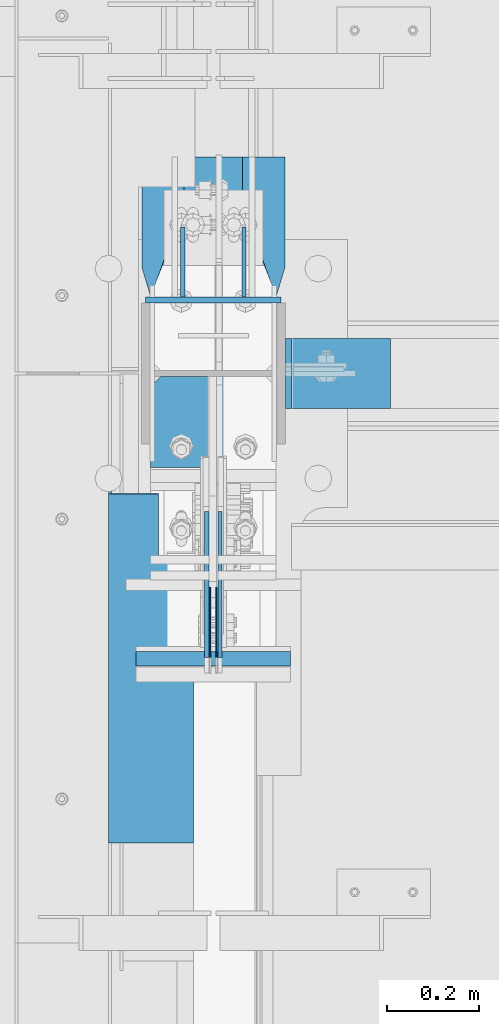
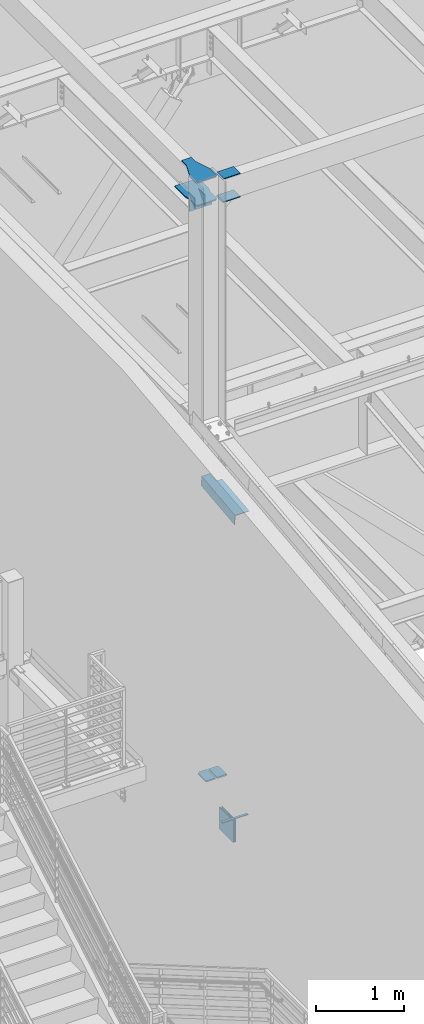
# One storey, part 870 of 1179: 15 beams, 8 elements without a shape of their own.
"""IFC2X3 building model written with IfcOpenShell, lengths in millimetres."""

from ifc_helpers import new_model, si_unit, frame, origin_with_axes, place, context, subcontext, project, spatial, faceted_brep, material, type_object, element, aggregate, save


model = new_model("IFC2X3")

# Units and contexts
model_context = context("Model", 3, precision=1e-05, world=origin_with_axes())
body_context = subcontext(model_context, "Body", "Model", "MODEL_VIEW")
ifc_project = project(units=[si_unit("LENGTHUNIT", "METRE", prefix="MILLI"), si_unit("AREAUNIT", "SQUARE_METRE"), si_unit("VOLUMEUNIT", "CUBIC_METRE"), si_unit("MASSUNIT", "GRAM", prefix="KILO"), si_unit("TIMEUNIT", "SECOND"), si_unit("PLANEANGLEUNIT", "RADIAN"), si_unit("SOLIDANGLEUNIT", "STERADIAN"), si_unit("THERMODYNAMICTEMPERATUREUNIT", "DEGREE_CELSIUS"), si_unit("LUMINOUSINTENSITYUNIT", "LUMEN")], contexts=[model_context])

# Site, building, storey
site_placement = place(None, origin_with_axes())
site = spatial("IfcSite", under=ifc_project, at=site_placement, CompositionType="ELEMENT")
building_placement = place(site_placement, origin_with_axes())
building = spatial("IfcBuilding", under=site, at=building_placement, Name="Undefined", CompositionType="ELEMENT")
storey_placement = place(building_placement, origin_with_axes())
storey = spatial("IfcBuildingStorey", under=building, at=storey_placement, Name="Undefined", CompositionType="ELEMENT", Elevation=0.0)

# Assembly, beam
assembly_1_placement = place(storey_placement, origin_with_axes())
assembly_1 = element("IfcElementAssembly", 1, at=assembly_1_placement, inside=storey, Name="BEAM", AssemblyPlace="NOTDEFINED", PredefinedType="RIGID_FRAME")
ifc_material_1 = material(Name="STEEL/A572-GR.50")
beam_type_1 = type_object("IfcBeamType", PredefinedType="NOTDEFINED")
beam_1_placement = place(assembly_1_placement, frame((431.80003662088, 33754.0407939301, 7989.4905), z_axis=(-1.0, 0.0, 0.0), x_axis=(0.0, 1.0, 0.0)))
beam_1 = element("IfcBeam", 2, at=beam_1_placement, type_object=beam_type_1, material=ifc_material_1, Name="PLATE", context=body_context, shape_type="Brep", body=[
    faceted_brep([(0.0, 4.76249999999982, -168.275000000001), (0.0, 4.76250000000073, 168.275), (31.75, 4.76249999999982, 168.275000000001), (31.75, 4.76249999999982, -168.275000000001), (0.0, -4.76250000000073, 168.275), (31.75, -4.76249999999982, 168.275000000001), (0.0, -4.76249999999982, -168.275000000001), (31.75, -4.76249999999982, -168.275000000001)], [[[0, 1, 2, 3]], [[1, 4, 5, 2]], [[4, 6, 7, 5]], [[6, 0, 3, 7]], [[5, 7, 3, 2]], [[6, 4, 1, 0]]]),
])

# Assembly, beams
assembly_2_placement = place(storey_placement, origin_with_axes())
assembly_2 = element("IfcElementAssembly", 3, at=assembly_2_placement, inside=storey, Name="COLUMN", AssemblyPlace="NOTDEFINED", PredefinedType="RIGID_FRAME")
ifc_material_2 = material(Name="STEEL/A36")
beam_type_2 = type_object("IfcBeamType", PredefinedType="NOTDEFINED")
beam_2_placement = place(assembly_2_placement, frame((579.437499999999, 34551.9375000406, 16030.575), z_axis=(0.0, 0.0, 1.0), x_axis=(-1.0, 0.0, 0.0)))
beam_2 = element("IfcBeam", 4, at=beam_2_placement, type_object=beam_type_2, material=ifc_material_2, Name="PLATE", context=body_context, shape_type="Brep", body=[
    faceted_brep([(-7.27595761418343e-12, 6.35000000000036, -76.1999999999971), (0.0, 6.35000000000036, 76.2000000000044), (295.274999999994, 6.34999999999854, 76.2000000000007), (295.274999999994, 6.34999999999854, -76.2000000000007), (0.0, -6.35000000000036, 76.2000000000044), (295.274999999994, -6.34999999999854, 76.2000000000007), (7.27595761418343e-12, -6.35000000000036, -76.1999999999971), (295.274999999994, -6.34999999999854, -76.2000000000007)], [[[0, 1, 2, 3]], [[1, 4, 5, 2]], [[4, 6, 7, 5]], [[6, 0, 3, 7]], [[5, 7, 3, 2]], [[6, 4, 1, 0]]]),
])
beam_3_placement = place(assembly_2_placement, frame((817.562493896483, 34391.6, 16116.3), z_axis=(0.0, 1.0, 0.0), x_axis=(-1.0, 0.0, 0.0)))
beam_3 = element("IfcBeam", 5, at=beam_3_placement, type_object=beam_type_2, material=ifc_material_2, Name="PLATE", context=body_context, shape_type="Brep", body=[
    faceted_brep([(215.900000000001, 6.35000000000036, 76.2000000000007), (228.599999999999, -6.35000000000036, 76.2000000000007), (228.599999999999, -6.35000000000036, -76.2000000000007), (215.900000000001, 6.35000000000036, -76.2000000000007), (-7.27595761418343e-12, 6.35000000000036, -76.1999999999971), (0.0, 6.35000000000036, 76.2000000000044), (0.0, -6.35000000000036, 76.2000000000044), (7.27595761418343e-12, -6.35000000000036, -76.1999999999971)], [[[0, 1, 2, 3]], [[4, 5, 0, 3]], [[5, 6, 1, 0]], [[6, 7, 2, 1]], [[7, 4, 3, 2]], [[7, 6, 5, 4]]]),
])
beam_4_placement = place(assembly_2_placement, frame((817.562494014754, 34391.6, 16435.3875), z_axis=(0.0, 1.0, 0.0), x_axis=(-1.0, 0.0, 0.0)))
beam_4 = element("IfcBeam", 6, at=beam_4_placement, type_object=beam_type_2, material=ifc_material_2, Name="PLATE", context=body_context, shape_type="Brep", body=[
    faceted_brep([(215.900000000001, 6.35000000000036, 76.2000000000007), (228.599999999999, -6.35000000000036, 76.2000000000007), (228.599999999999, -6.35000000000036, -76.2000000000007), (215.900000000001, 6.35000000000036, -76.2000000000007), (-7.27595761418343e-12, 6.35000000000036, -76.1999999999971), (0.0, 6.35000000000036, 76.2000000000044), (0.0, -6.35000000000036, 76.2000000000044), (7.27595761418343e-12, -6.35000000000036, -76.1999999999971)], [[[0, 1, 2, 3]], [[4, 5, 0, 3]], [[5, 6, 1, 0]], [[6, 7, 2, 1]], [[7, 4, 3, 2]], [[7, 6, 5, 4]]]),
])

# Assembly, beam
assembly_3_placement = place(storey_placement, origin_with_axes())
assembly_3 = element("IfcElementAssembly", 7, at=assembly_3_placement, inside=storey, Name="PLATE", AssemblyPlace="NOTDEFINED", PredefinedType="RIGID_FRAME")
beam_type_3 = type_object("IfcBeamType", PredefinedType="NOTDEFINED")
beam_5_placement = place(assembly_3_placement, frame((358.775000000002, 34186.8125, 8286.54312047043), z_axis=(-1.0, 0.0, 0.0), x_axis=(0.0, 1.0, 0.0)))
beam_5 = element("IfcBeam", 8, at=beam_5_placement, type_object=beam_type_3, material=ifc_material_1, Name="PLATE", context=body_context, shape_type="Brep", body=[
    faceted_brep([(198.437500000007, 9.52499999999964, 41.275), (176.212500000009, 9.52499999999964, 63.5), (176.212500000009, -9.52499999999964, 63.5), (198.437500000007, -9.52499999999964, 41.275), (198.4375, 9.52499999999964, -63.5), (0.0, 9.52500000000146, -63.5), (0.0, 9.52500000000146, 63.5), (0.0, -9.52500000000146, 63.5), (0.0, -9.52500000000146, -63.5), (198.4375, -9.52499999999964, -63.5)], [[[0, 1, 2, 3]], [[4, 5, 6, 1, 0]], [[6, 7, 2, 1]], [[7, 8, 9, 3, 2]], [[8, 5, 4, 9]], [[9, 4, 0, 3]], [[8, 7, 6, 5]]]),
])
aggregate(assembly_3, [beam_5])

assembly_4_placement = place(storey_placement, origin_with_axes())
assembly_4 = element("IfcElementAssembly", 9, at=assembly_4_placement, inside=storey, Name="PLATE", AssemblyPlace="NOTDEFINED", PredefinedType="RIGID_FRAME")
beam_6_placement = place(assembly_4_placement, frame((504.825000000001, 34186.8125, 8286.54312047043), z_axis=(-1.0, 0.0, 0.0), x_axis=(0.0, 1.0, 0.0)))
beam_6 = element("IfcBeam", 10, at=beam_6_placement, type_object=beam_type_3, material=ifc_material_1, Name="PLATE", context=body_context, shape_type="Brep", body=[
    faceted_brep([(176.212500000009, 9.52499999999964, -63.5), (198.437500000007, 9.52499999999964, -41.275), (198.437500000007, -9.52499999999964, -41.275), (176.212500000009, -9.52499999999964, -63.5), (0.0, 9.52500000000146, -63.5), (0.0, 9.52500000000146, 63.5), (198.4375, 9.52499999999964, 63.5), (0.0, -9.52500000000146, 63.5), (198.4375, -9.52499999999964, 63.5), (0.0, -9.52500000000146, -63.5)], [[[0, 1, 2, 3]], [[4, 5, 6, 1, 0]], [[5, 7, 8, 6]], [[8, 7, 9, 3, 2]], [[9, 4, 0, 3]], [[6, 8, 2, 1]], [[9, 7, 5, 4]]]),
])
aggregate(assembly_4, [beam_6])

assembly_5_placement = place(storey_placement, origin_with_axes())
assembly_5 = element("IfcElementAssembly", 11, at=assembly_5_placement, inside=storey, Name="BEAM", AssemblyPlace="NOTDEFINED", PredefinedType="RIGID_FRAME")
beam_type_4 = type_object("IfcBeamType", PredefinedType="NOTDEFINED")
beam_7_placement = place(assembly_5_placement, frame((388.937000010137, 33749.3243625856, 12534.8982577427), z_axis=(0.0, -0.993676146336441, -0.112284087038017), x_axis=(-1.0, 0.0, 0.0)))
beam_7 = element("IfcBeam", 12, at=beam_7_placement, type_object=beam_type_4, material=ifc_material_2, Name="BENT_PLATE", context=body_context, shape_type="Brep", body=[
    faceted_brep([(76.1995000095473, -3.1744942565474, -236.537500018901), (76.1995000095473, 3.17611935720561, -236.537500021412), (76.1995000095473, 3.17500000011933, -382.58750000118), (76.1995000095473, -3.1749999998774, -382.587500001187), (-4.5588421926368e-11, -3.17499999980828, -236.537500018901), (-2.98427949019242e-11, 3.17500000018845, -236.537500021404), (179.387000009598, 3.17499999924075, 382.587500001137), (6.88373802404385e-11, 3.17499999968459, 382.587500001166), (5.31485966348555e-11, -3.17500000031214, 382.587500001166), (185.737000009598, -3.17500000077234, 382.587500001137), (185.7370000095, 136.524999985873, 382.587500001166), (179.3870000095, 136.524999985873, 382.587500001166), (179.387000009313, 3.17499999986285, -382.587500001202), (179.387000009413, 136.524999986321, -382.58750000118), (185.737000009413, 136.524999986321, -382.58750000118), (185.737000009313, -3.17500000015025, -382.587500001202)], [[[0, 1, 2, 3]], [[4, 5, 1, 0]], [[6, 7, 8, 9, 10, 11]], [[12, 6, 11, 13]], [[10, 14, 13, 11]], [[9, 15, 14, 10]], [[12, 13, 14, 15, 3, 2]], [[7, 6, 12, 2, 1, 5]], [[8, 7, 5, 4]], [[15, 9, 8, 4, 0, 3]]]),
])
aggregate(assembly_5, [beam_7])

# Beam
beam_type_5 = type_object("IfcBeamType", PredefinedType="NOTDEFINED")
beam_8_placement = place(assembly_1_placement, frame((424.656250000001, 33925.4907939295, 7804.15), z_axis=(0.0, 0.0, -1.0), x_axis=(0.0, -1.0, 0.0)))
beam_8 = element("IfcBeam", 13, at=beam_8_placement, type_object=beam_type_5, material=ifc_material_1, Name="PLATE", context=body_context, shape_type="Brep", body=[
    faceted_brep([(0.0, 1.58750000000146, -152.4), (0.0, 1.58750000000146, 152.4), (152.400000000009, 1.58750000000146, 152.4), (152.400000000009, 1.58750000000146, -152.4), (0.0, -1.58750000000146, 152.4), (152.400000000009, -1.58750000000146, 152.4), (0.0, -1.58750000000146, -152.4), (152.400000000009, -1.58750000000146, -152.4)], [[[0, 1, 2, 3]], [[1, 4, 5, 2]], [[4, 6, 7, 5]], [[6, 0, 3, 7]], [[5, 7, 3, 2]], [[6, 4, 1, 0]]]),
])

beam_9_placement = place(assembly_1_placement, frame((438.943750000001, 33925.4907939295, 7804.15), z_axis=(0.0, 0.0, -1.0), x_axis=(0.0, -1.0, 0.0)))
beam_9 = element("IfcBeam", 14, at=beam_9_placement, type_object=beam_type_5, material=ifc_material_1, Name="PLATE", context=body_context, shape_type="Brep", body=[
    faceted_brep([(0.0, 1.58750000000146, -152.4), (0.0, 1.58750000000146, 152.4), (152.400000000009, 1.58750000000146, 152.4), (152.400000000009, 1.58750000000146, -152.4), (0.0, -1.58750000000146, 152.4), (152.400000000009, -1.58750000000146, 152.4), (0.0, -1.58750000000146, -152.4), (152.400000000009, -1.58750000000146, -152.4)], [[[0, 1, 2, 3]], [[1, 4, 5, 2]], [[4, 6, 7, 5]], [[6, 0, 3, 7]], [[5, 7, 3, 2]], [[6, 4, 1, 0]]]),
])

aggregate(assembly_1, [beam_8, beam_9, beam_1])

# Assembly, beam
assembly_6_placement = place(storey_placement, origin_with_axes())
assembly_6 = element("IfcElementAssembly", 15, at=assembly_6_placement, inside=storey, Name="PLATE", AssemblyPlace="NOTDEFINED", PredefinedType="RIGID_FRAME")
beam_type_6 = type_object("IfcBeamType", PredefinedType="NOTDEFINED")
beam_10_placement = place(assembly_6_placement, frame((417.512786388181, 33773.0907939296, 7804.15), z_axis=(0.0, 0.0, -1.0), x_axis=(0.0, 1.0, 0.0)))
beam_10 = element("IfcBeam", 16, at=beam_10_placement, type_object=beam_type_6, material=ifc_material_1, Name="PLATE", context=body_context, shape_type="Brep", body=[
    faceted_brep([(0.0, 4.76250000000073, -152.4), (0.0, 4.76250000000073, 152.4), (317.5, 4.76250000000073, 152.4), (317.5, 4.76250000000073, -152.4), (0.0, -4.76250000000073, 152.4), (317.5, -4.76250000000073, 152.4), (0.0, -4.76250000000073, -152.4), (317.5, -4.76250000000073, -152.4)], [[[0, 1, 2, 3]], [[1, 4, 5, 2]], [[4, 6, 7, 5]], [[6, 0, 3, 7]], [[5, 7, 3, 2]], [[6, 4, 1, 0]]]),
])
aggregate(assembly_6, [beam_10])

assembly_7_placement = place(storey_placement, origin_with_axes())
assembly_7 = element("IfcElementAssembly", 17, at=assembly_7_placement, inside=storey, Name="PLATE", AssemblyPlace="NOTDEFINED", PredefinedType="RIGID_FRAME")
beam_11_placement = place(assembly_7_placement, frame((446.087213611823, 34090.5907939296, 7804.15), z_axis=(0.0, 0.0, -1.0), x_axis=(0.0, -1.0, 0.0)))
beam_11 = element("IfcBeam", 18, at=beam_11_placement, type_object=beam_type_6, material=ifc_material_1, Name="PLATE", context=body_context, shape_type="Brep", body=[
    faceted_brep([(0.0, 4.76250000000073, -152.4), (0.0, 4.76250000000073, 152.4), (317.5, 4.76250000000073, 152.4), (317.5, 4.76250000000073, -152.4), (0.0, -4.76250000000073, 152.4), (317.5, -4.76250000000073, 152.4), (0.0, -4.76250000000073, -152.4), (317.5, -4.76250000000073, -152.4)], [[[0, 1, 2, 3]], [[1, 4, 5, 2]], [[4, 6, 7, 5]], [[6, 0, 3, 7]], [[5, 7, 3, 2]], [[6, 4, 1, 0]]]),
])
aggregate(assembly_7, [beam_11])

# Beam
beam_type_7 = type_object("IfcBeamType", PredefinedType="NOTDEFINED")
beam_12_placement = place(assembly_2_placement, frame((498.475000000001, 34710.6875000406, 16030.575), z_axis=(0.0, 0.0, 1.0), x_axis=(0.0, -1.0, 0.0)))
beam_12 = element("IfcBeam", 19, at=beam_12_placement, type_object=beam_type_7, material=ifc_material_2, Name="PLATE", context=body_context, shape_type="Brep", body=[
    faceted_brep([(152.4, -4.76249999999709, 76.2), (152.4, -4.76249999999709, -76.2), (152.4, 4.76249999999709, -76.2), (152.4, 4.76249999999709, 76.2), (0.0, 4.76249999999982, 76.1999999999971), (0.0, -4.76249999999982, 76.1999999999971)], [[[0, 1, 2, 3]], [[3, 2, 4]], [[4, 5, 0, 3]], [[0, 5, 1]], [[4, 2, 1, 5]]]),
])

beam_13_placement = place(assembly_2_placement, frame((365.125000000002, 34710.6875000406, 16030.575), z_axis=(0.0, 0.0, 1.0), x_axis=(0.0, -1.0, 0.0)))
beam_13 = element("IfcBeam", 20, at=beam_13_placement, type_object=beam_type_7, material=ifc_material_2, Name="PLATE", context=body_context, shape_type="Brep", body=[
    faceted_brep([(152.4, -4.76249999999709, 76.2), (152.4, -4.76249999999709, -76.2), (152.4, 4.76249999999709, -76.2), (152.4, 4.76249999999709, 76.2), (0.0, 4.76249999999982, 76.1999999999971), (0.0, -4.76249999999982, 76.1999999999971)], [[[0, 1, 2, 3]], [[3, 2, 4]], [[4, 5, 0, 3]], [[0, 5, 1]], [[4, 2, 1, 5]]]),
])

beam_type_8 = type_object("IfcBeamType", PredefinedType="NOTDEFINED")
beam_14_placement = place(assembly_2_placement, frame((431.800000000002, 34863.0875000406, 16114.7125), z_axis=(-1.0, 0.0, 0.0), x_axis=(0.0, -1.0, 0.0)))
beam_14 = element("IfcBeam", 21, at=beam_14_placement, type_object=beam_type_8, material=ifc_material_2, Name="PLATE", context=body_context, shape_type="Brep", body=[
    faceted_brep([(465.137499999997, -7.9375, -114.300000762945), (442.912499999999, -7.9375, -136.525000762944), (442.912500000006, 7.9375, -136.525000762944), (465.137500000004, 7.9375, -114.300000762945), (465.137500000004, 7.9375, 114.300000762938), (442.912500000006, 7.9375, 136.525000762937), (442.912499999999, -7.9375, 136.525000762937), (465.137499999997, -7.9375, 114.300000762938), (241.300006103491, -7.9375, -155.575000000001), (241.300006103491, 7.9375, -155.575000000001), (304.799990844724, 7.9375, -136.525000762944), (304.799990844724, -7.9375, -136.525000762944), (0.0, -7.9375, -155.575000000001), (0.0, -7.9375, 155.575000000001), (0.0, 7.9375, 155.575000000001), (0.0, 7.9375, -155.575000000001), (241.300006103513, -7.9375, 155.575000000001), (241.300006103513, 7.9375, 155.575000000001), (304.799990844724, -7.9375, 136.525000762937), (304.799990844724, 7.9375, 136.525000762937)], [[[0, 1, 2, 3]], [[4, 5, 6, 7]], [[8, 9, 10, 11]], [[11, 10, 2, 1]], [[12, 13, 14, 15]], [[14, 13, 16, 17]], [[18, 19, 17, 16]], [[19, 18, 6, 5]], [[4, 7, 0, 3]], [[10, 9, 15, 14, 17, 19, 5, 4, 3, 2]], [[12, 15, 9, 8]], [[7, 6, 18, 16, 13, 12, 8, 11, 1, 0]]]),
])

aggregate(assembly_2, [beam_12, beam_13, beam_14, beam_2, beam_3, beam_4])

# Assembly, beam
assembly_8_placement = place(storey_placement, origin_with_axes())
assembly_8 = element("IfcElementAssembly", 22, at=assembly_8_placement, inside=storey, Name="PLATE", AssemblyPlace="NOTDEFINED", PredefinedType="RIGID_FRAME")
beam_type_9 = type_object("IfcBeamType", PredefinedType="NOTDEFINED")
beam_15_placement = place(assembly_8_placement, frame((431.800000000002, 34863.0875000406, 16435.3875), z_axis=(-1.0, 0.0, 0.0), x_axis=(0.0, -1.0, 0.0)))
beam_15 = element("IfcBeam", 23, at=beam_15_placement, type_object=beam_type_9, material=ifc_material_2, Name="PLATE", context=body_context, shape_type="Brep", body=[
    faceted_brep([(465.137499999997, -7.9375, -114.300000762945), (442.912499999999, -7.9375, -136.525000762944), (442.912500000006, 7.9375, -136.525000762944), (465.137500000004, 7.9375, -114.300000762945), (465.137500000004, 7.9375, 114.300000762938), (442.912500000006, 7.9375, 136.525000762937), (442.912499999999, -7.9375, 136.525000762937), (465.137499999997, -7.9375, 114.300000762938), (97.1744871646697, -7.9375, 63.4999984741225), (97.1744871646697, 7.9375, 63.4999984741225), (0.0, 7.9375, 63.5), (0.0, -7.9375, 63.5), (99.3625358760146, -7.9375, 63.5944172169256), (99.3625358760146, 7.9375, 63.5944172169256), (101.534317436837, -7.9375, 63.8769714847585), (101.534317436837, 7.9375, 63.8769714847585), (103.673685635511, -7.9375, 64.3455606147181), (103.673685635511, 7.9375, 64.3455606147181), (105.764735239063, -7.9375, 64.9967008589738), (105.764735239063, 7.9375, 64.9967008589738), (304.799990844724, -7.9375, 136.525000762937), (304.799990844724, 7.9375, 136.525000762937), (0.0, -7.9375, -63.5), (0.0, 7.9375, -63.5), (97.1744871646697, 7.9375, -63.5), (97.1744871646697, -7.9375, -63.5), (99.3625358760146, 7.9375, -63.5944187428031), (99.3625358760146, -7.9375, -63.5944187428031), (101.534317436837, 7.9375, -63.876973010636), (101.534317436837, -7.9375, -63.876973010636), (103.673685635511, 7.9375, -64.3455621405956), (103.673685635511, -7.9375, -64.3455621405956), (105.764735239063, 7.9375, -64.9967023848512), (105.764735239063, -7.9375, -64.9967023848512), (304.799990844724, -7.9375, -136.525000762944), (304.799990844724, 7.9375, -136.525000762944)], [[[0, 1, 2, 3]], [[4, 5, 6, 7]], [[8, 9, 10, 11]], [[12, 13, 9, 8]], [[14, 15, 13, 12]], [[16, 17, 15, 14]], [[18, 19, 17, 16]], [[20, 21, 19, 18]], [[22, 23, 24, 25]], [[25, 24, 26, 27]], [[27, 26, 28, 29]], [[29, 28, 30, 31]], [[31, 30, 32, 33]], [[34, 33, 32, 35]], [[34, 35, 2, 1]], [[4, 7, 0, 3]], [[7, 6, 20, 18, 16, 14, 12, 8, 11, 22, 25, 27, 29, 31, 33, 34, 1, 0]], [[22, 11, 10, 23]], [[35, 32, 30, 28, 26, 24, 23, 10, 9, 13, 15, 17, 19, 21, 5, 4, 3, 2]], [[21, 20, 6, 5]]]),
])
aggregate(assembly_8, [beam_15])

save(model, "model.ifc")
